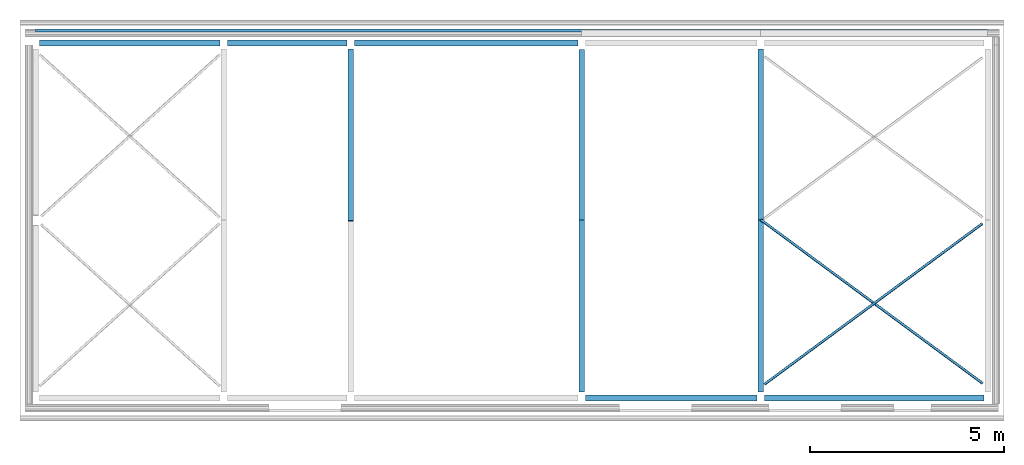
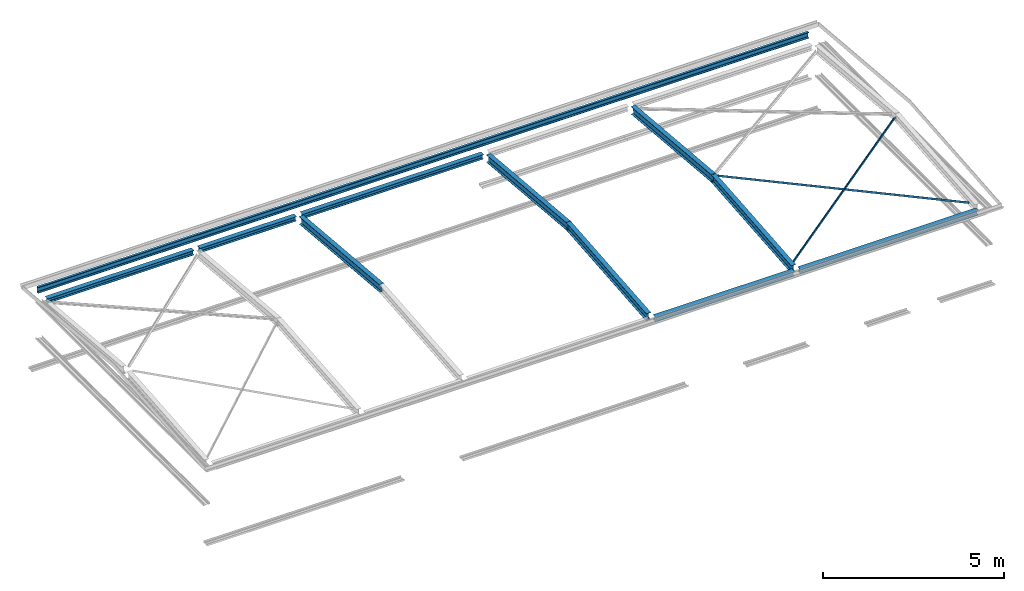
# One storey, part 2 of 8: 13 beams.
"""IFC2X3 building model written with IfcOpenShell, lengths in millimetres."""

import ifcopenshell
import ifcopenshell.guid

model = None  # the IFC model being written
_history = None  # IfcOwnerHistory: only IFC2X3 demands one
_inside = {}  # id of a spatial element -> (the spatial element, [elements in it])
_under = {}  # id of a project, library or spatial element -> (it, [spatial elements below it])
_declared = {}  # id of a project -> (the project, [libraries it declares])
_typed = {}  # id of a type object -> (the type object, [elements of that type])
_made_of = {}  # id of a material, layer set ... -> (it, [elements and type objects made of it])


def new_model(schema):
    """Start an empty IFC model of exactly this schema.

    Asked for "IFC4X3", IfcOpenShell would pick the latest addendum, in which some entities
    have other attributes; the version numbers below select the first issue.
    IFC2X3 requires an IfcOwnerHistory on every rooted entity: one is made here for all.
    """
    global model, _history
    if schema == "IFC4X3":
        model = ifcopenshell.file(schema_version=(4, 3, 0, 0))
    else:
        model = ifcopenshell.file(schema=schema)
    _inside.clear()
    _under.clear()
    _declared.clear()
    _typed.clear()
    _made_of.clear()
    _history = None
    if model.schema == "IFC2X3":
        org = make("IfcOrganization", Name="unknown")
        user = make(
            "IfcPersonAndOrganization",
            ThePerson=make("IfcPerson", FamilyName="unknown"),
            TheOrganization=org,
        )
        app = make(
            "IfcApplication",
            ApplicationDeveloper=org,
            Version="unknown",
            ApplicationFullName="unknown",
            ApplicationIdentifier="unknown",
        )
        _history = make(
            "IfcOwnerHistory",
            OwningUser=user,
            OwningApplication=app,
            ChangeAction="ADDED",
            CreationDate=0,
        )
    return model


def make(cls, **values):
    """One entity of the class cls with the attributes given. An attribute that is None is left unset."""
    return model.create_entity(
        cls, **{name: value for name, value in values.items() if value is not None}
    )


def entity(cls, *values):
    """Any entity or typed value of the class cls, its attributes in the order of the schema. None: left unset."""
    e = model.create_entity(cls)
    for i, value in enumerate(values):
        if value is not None:
            e[i] = value
    return e


def rooted(cls, **values):
    """An entity with a GlobalId (a new one), such as an element, a storey or a relation."""
    return make(cls, GlobalId=ifcopenshell.guid.new(), OwnerHistory=_history, **values)


def si_unit(unit_type, name, prefix=None):
    """IfcSIUnit, for example si_unit("LENGTHUNIT", "METRE", prefix="MILLI")."""
    return make("IfcSIUnit", UnitType=unit_type, Prefix=prefix, Name=name)


def converted_unit(unit_type, name, factor, base, dimensions=None, offset=None):
    """IfcConversionBasedUnit, such as the inch: factor (a typed value) times the base unit."""
    return make(
        "IfcConversionBasedUnit"
        if offset is None
        else "IfcConversionBasedUnitWithOffset",
        ConversionOffset=offset,
        Dimensions=None
        if dimensions is None
        else entity("IfcDimensionalExponents", *dimensions),
        UnitType=unit_type,
        Name=name,
        ConversionFactor=make(
            "IfcMeasureWithUnit", ValueComponent=factor, UnitComponent=base
        ),
    )


def money_unit(currency):
    """IfcMonetaryUnit."""
    return make("IfcMonetaryUnit", Currency=currency)


def assignment(units):
    """IfcUnitAssignment: the units of a project."""
    return None if units is None else make("IfcUnitAssignment", Units=units)


def point(xyz):
    """IfcCartesianPoint."""
    return None if xyz is None else make("IfcCartesianPoint", Coordinates=xyz)


def direction(xyz):
    """IfcDirection."""
    return None if xyz is None else make("IfcDirection", DirectionRatios=xyz)


def frame(location, z_axis=None, x_axis=None):
    """IfcAxis2Placement3D, a coordinate frame: its origin and axes. An axis left out is left unset."""
    return make(
        "IfcAxis2Placement3D",
        Location=point(location),
        Axis=direction(z_axis),
        RefDirection=direction(x_axis),
    )


def frame_2d(location, x_axis=None):
    """IfcAxis2Placement2D, a coordinate frame in the plane: its origin and x axis."""
    return make(
        "IfcAxis2Placement2D", Location=point(location), RefDirection=direction(x_axis)
    )


def origin_with_axes():
    """The frame at (0, 0, 0) with the z axis (0, 0, 1) and the x axis (1, 0, 0) written out."""
    return frame((0.0, 0.0, 0.0), z_axis=(0.0, 0.0, 1.0), x_axis=(1.0, 0.0, 0.0))


def place(relative_to, where):
    """IfcLocalPlacement: puts the frame where relative to a parent placement (None: the world)."""
    return make(
        "IfcLocalPlacement", PlacementRelTo=relative_to, RelativePlacement=where
    )


def context(
    kind, dimensions, precision=None, world=None, true_north=None, identifier=None
):
    """IfcGeometricRepresentationContext, for example the 3D "Model" context."""
    return make(
        "IfcGeometricRepresentationContext",
        ContextIdentifier=identifier,
        ContextType=kind,
        CoordinateSpaceDimension=dimensions,
        Precision=precision,
        WorldCoordinateSystem=world,
        TrueNorth=true_north,
    )


def subcontext(parent, identifier, kind, view, scale=None):
    """IfcGeometricRepresentationSubContext, for example "Body" below "Model"."""
    return make(
        "IfcGeometricRepresentationSubContext",
        ContextIdentifier=identifier,
        ContextType=kind,
        ParentContext=parent,
        TargetScale=scale,
        TargetView=view,
    )


def project(units=None, contexts=None):
    """IfcProject with its units and contexts."""
    return rooted(
        "IfcProject",
        Name="project",
        RepresentationContexts=contexts,
        UnitsInContext=assignment(units),
    )


def spatial(cls, under=None, at=None, **own):
    """A site, building, storey or space (cls), placed at a placement, below another one or the project."""
    s = rooted(cls, ObjectPlacement=at, **own)
    if under is not None:
        _under.setdefault(under.id(), (under, []))[1].append(s)
    return s


def polyline(points):
    """IfcPolyline through the points."""
    return make("IfcPolyline", Points=[point(p) for p in points])


def circle_curve(where, radius):
    """IfcCircle in the frame where."""
    return make("IfcCircle", Position=where, Radius=radius)


def parameter(value):
    """IfcParameterValue: where a trimmed curve begins or ends, as a parameter of its basis curve."""
    return model.create_entity("IfcParameterValue", value)


def trimmed(basis, trim1, trim2, sense, master):
    """IfcTrimmedCurve: the piece of a basis curve between two trims."""
    return make(
        "IfcTrimmedCurve",
        BasisCurve=basis,
        Trim1=trim1,
        Trim2=trim2,
        SenseAgreement=sense,
        MasterRepresentation=master,
    )


def segment(curve, same_sense, transition):
    """IfcCompositeCurveSegment."""
    return make(
        "IfcCompositeCurveSegment",
        Transition=transition,
        SameSense=same_sense,
        ParentCurve=curve,
    )


def composite_curve(segments, self_intersect=None):
    """IfcCompositeCurve: segments joined end to end."""
    return make("IfcCompositeCurve", Segments=segments, SelfIntersect=self_intersect)


def outline(outer, holes=None, kind="AREA"):
    """IfcArbitraryClosedProfileDef: a profile drawn as a closed curve; with holes, ...WithVoids."""
    if holes is None:
        return make("IfcArbitraryClosedProfileDef", ProfileType=kind, OuterCurve=outer)
    return make(
        "IfcArbitraryProfileDefWithVoids",
        ProfileType=kind,
        OuterCurve=outer,
        InnerCurves=holes,
    )


def extrude(swept, where, along, depth):
    """IfcExtrudedAreaSolid: the profile swept, set in the frame where, extruded along a direction by depth."""
    return make(
        "IfcExtrudedAreaSolid",
        SweptArea=swept,
        Position=where,
        ExtrudedDirection=direction(along),
        Depth=depth,
    )


def clip(a, b, op="DIFFERENCE"):
    """IfcBooleanClippingResult: the solid a cut by the half space b."""
    return make(
        "IfcBooleanClippingResult", Operator=op, FirstOperand=a, SecondOperand=b
    )


def halfspace(plane, agree):
    """IfcHalfSpaceSolid: all space on one side of the plane z = 0 of the frame plane."""
    return make(
        "IfcHalfSpaceSolid",
        BaseSurface=make("IfcPlane", Position=plane),
        AgreementFlag=agree,
    )


def shape(context_of_items, identifier, shape_type, items):
    """IfcShapeRepresentation: the items that make up one representation, for example the "Body"."""
    return make(
        "IfcShapeRepresentation",
        ContextOfItems=context_of_items,
        RepresentationIdentifier=identifier,
        RepresentationType=shape_type,
        Items=items,
    )


def material(Name=None, Category=None):
    """IfcMaterial."""
    return make("IfcMaterial", Name=Name, Category=Category)


def made_of(thing, what):
    """Note that an element or type object is made of a material, layer set ...; save() writes the relation."""
    if what is not None:
        _made_of.setdefault(what.id(), (what, []))[1].append(thing)
    return thing


def type_object(cls, material=None, **own):
    """A type object (cls), such as IfcWallType, which elements share."""
    return made_of(rooted(cls, **own), material)


def element(
    cls,
    number,
    at=None,
    inside=None,
    cuts=None,
    type_object=None,
    material=None,
    context=None,
    identifier="Body",
    shape_type=None,
    held_by="IfcProductDefinitionShape",
    body=None,
    shapes=None,
    **own,
):
    """One element of the class cls, such as IfcWall. Its Tag is "e" and its number.

    at: its placement. inside: the storey or other place that contains it. cuts: it is an
    opening in that element (IfcRelVoidsElement). A single representation is given by context,
    identifier, shape_type and body (its items); several are given by shapes. held_by: the class
    of the entity that holds the representations. save() writes the other relations.
    """
    e = rooted(cls, Tag="e%d" % number, ObjectPlacement=at, **own)
    if body is not None:
        shapes = [shape(context, identifier, shape_type, body)]
    if shapes is not None:
        e.Representation = make(held_by, Representations=shapes)
    if inside is not None:
        _inside.setdefault(inside.id(), (inside, []))[1].append(e)
    if cuts is not None:
        rooted(
            "IfcRelVoidsElement", RelatingBuildingElement=cuts, RelatedOpeningElement=e
        )
    if type_object is not None:
        _typed.setdefault(type_object.id(), (type_object, []))[1].append(e)
    return made_of(e, material)


def aggregate(whole, parts):
    """IfcRelAggregates: a whole, such as a stair, and the parts it consists of."""
    return rooted("IfcRelAggregates", RelatingObject=whole, RelatedObjects=parts)


def save(model, path):
    """Write the relations noted so far, then the file.

    IfcRelAggregates (storeys below a building ...), IfcRelContainedInSpatialStructure (elements
    in a storey), IfcRelDefinesByType, IfcRelAssociatesMaterial and IfcRelDeclares: one each for
    every whole, place, type object, material and project.
    """
    for whole, parts in _under.values():
        aggregate(whole, parts)
    for where, things in _inside.values():
        rooted(
            "IfcRelContainedInSpatialStructure",
            RelatedElements=things,
            RelatingStructure=where,
        )
    for kind, things in _typed.values():
        rooted("IfcRelDefinesByType", RelatedObjects=things, RelatingType=kind)
    for what, things in _made_of.values():
        rooted("IfcRelAssociatesMaterial", RelatedObjects=things, RelatingMaterial=what)
    for by, libraries in _declared.values():
        rooted("IfcRelDeclares", RelatingContext=by, RelatedDefinitions=libraries)
    model.write(path)


model = new_model("IFC2X3")

# Units and contexts
model_context = context("Model", 3, precision=1e-05, world=origin_with_axes(), true_north=direction((0.0, 1.0)))
body_context = subcontext(model_context, "Body", "Model", "MODEL_VIEW")
ifc_project = project(units=[si_unit("LENGTHUNIT", "METRE", prefix="MILLI"), si_unit("AREAUNIT", "SQUARE_METRE"), si_unit("VOLUMEUNIT", "CUBIC_METRE"), converted_unit("PLANEANGLEUNIT", "DEGREE", entity("IfcPlaneAngleMeasure", 0.0174532925199), si_unit("PLANEANGLEUNIT", "RADIAN"), dimensions=[0, 0, 0, 0, 0, 0, 0]), si_unit("SOLIDANGLEUNIT", "STERADIAN"), money_unit("USD"), converted_unit("TIMEUNIT", "Year", entity("IfcTimeMeasure", 31556926.0), si_unit("TIMEUNIT", "SECOND"), dimensions=[0, 0, 0, 0, 0, 0, 0]), si_unit("MASSUNIT", "GRAM"), si_unit("THERMODYNAMICTEMPERATUREUNIT", "DEGREE_CELSIUS"), si_unit("LUMINOUSINTENSITYUNIT", "LUMEN")], contexts=[model_context])

# Site, building, storey
site_placement = place(None, origin_with_axes())
site = spatial("IfcSite", under=ifc_project, at=site_placement, CompositionType="ELEMENT")
building_placement = place(site_placement, origin_with_axes())
building = spatial("IfcBuilding", under=site, at=building_placement, CompositionType="ELEMENT")
storey_placement = place(building_placement, frame((0.0, 0.0, 74215.0), z_axis=(0.0, 0.0, 1.0), x_axis=(1.0, 0.0, 0.0)))
storey = spatial("IfcBuildingStorey", under=building, at=storey_placement, CompositionType="ELEMENT", Elevation=74215.0)

# Beams
ifc_material = material(Name="Metal - Steel 43-275")
beam_type_1 = type_object("IfcBeamType", Name="UB254x146x31 (1) 251 x 146", PredefinedType="NOTDEFINED")
beam_1_placement = place(storey_placement, frame((5946.1957886, 3613.7891505, 267.014681752), z_axis=(0.0, 0.0, 1.0), x_axis=(-1.0, 0.0, 0.0)))
element("IfcBeam", 1, at=beam_1_placement, inside=storey, type_object=beam_type_1, material=ifc_material, Name="UB-Universal Beams:UB254x146x31", ObjectType="UB-Universal Beams:UB254x146x31", context=body_context, shape_type="Clipping", body=[
    clip(clip(clip(clip(extrude(outline(composite_curve([segment(polyline([(125.7, 73.05), (117.1, 73.05), (117.1, 10.6)]), True, "CONTINUOUS"), segment(trimmed(circle_curve(frame_2d((109.5, 10.6), x_axis=(0.0, -1.0)), 7.6), [point((117.1, 10.6)), parameter(90.0)], [point((109.5, 3.0)), parameter(0.0)], False, "CARTESIAN"), True, "CONTINUOUS"), segment(polyline([(109.5, 3.0), (-109.5, 3.0)]), True, "CONTINUOUS"), segment(trimmed(circle_curve(frame_2d((-109.5, 10.6), x_axis=(-1.0, 0.0)), 7.6), [point((-109.5, 3.0)), parameter(90.0)], [point((-117.1, 10.6)), parameter(0.0)], False, "CARTESIAN"), True, "CONTINUOUS"), segment(polyline([(-117.1, 10.6), (-117.1, 73.05), (-125.7, 73.05), (-125.7, -73.05), (-117.1, -73.05), (-117.1, -10.6)]), True, "CONTINUOUS"), segment(trimmed(circle_curve(frame_2d((-109.5, -10.6), x_axis=(0.0, 1.0)), 7.6), [point((-117.1, -10.6)), parameter(90.0)], [point((-109.5, -3.0)), parameter(0.0)], False, "CARTESIAN"), True, "CONTINUOUS"), segment(polyline([(-109.5, -3.0), (109.5, -3.0)]), True, "CONTINUOUS"), segment(trimmed(circle_curve(frame_2d((109.5, -10.6), x_axis=(1.0, 0.0)), 7.6), [point((109.5, -3.0)), parameter(90.0)], [point((117.1, -10.6)), parameter(0.0)], False, "CARTESIAN"), True, "CONTINUOUS"), segment(polyline([(117.1, -10.6), (117.1, -73.05), (125.7, -73.05), (125.7, 73.05)]), True, "CONTINUOUS")], self_intersect=False)), frame((0.0, 4482.93411635, -395.427760455), z_axis=(0.0, -0.996132286365, 0.08786619408), x_axis=(0.0, -0.08786619408, -0.996132286365)), (0.0, 0.0, 1.0), 4518.56524717), halfspace(frame((0.0, 4446.62488753, -392.225019424), z_axis=(0.0, -0.996132286365, 0.08786619408), x_axis=(0.0, -0.08786619408, -0.996132286365)), True)), halfspace(frame((0.0, 18.1546144043, -1.60137051527), z_axis=(0.0, 0.996132286365, -0.08786619408), x_axis=(0.0, 0.08786619408, 0.996132286365)), True)), halfspace(frame((0.0, 4464.77950194, 0.0), z_axis=(0.0, -1.0, 0.0), x_axis=(0.0, 0.0, -1.0)), True)), halfspace(frame((0.0, 0.0, 0.0), z_axis=(0.0, 1.0, 0.0), x_axis=(0.0, 0.0, 1.0)), True)),
])
beam_2_placement = place(storey_placement, frame((10556.4041262, 3541.17069288, 267.014681752), z_axis=(0.0, 0.0, 1.0), x_axis=(1.0, 0.0, 0.0)))
element("IfcBeam", 2, at=beam_2_placement, inside=storey, type_object=beam_type_1, material=ifc_material, Name="UB-Universal Beams:UB254x146x31", ObjectType="UB-Universal Beams:UB254x146x31", context=body_context, shape_type="Clipping", body=[
    clip(clip(clip(clip(extrude(outline(composite_curve([segment(polyline([(125.7, 73.05), (117.1, 73.05), (117.1, 10.6)]), True, "CONTINUOUS"), segment(trimmed(circle_curve(frame_2d((109.5, 10.6), x_axis=(0.0, -1.0)), 7.6), [point((117.1, 10.6)), parameter(90.0)], [point((109.5, 3.0)), parameter(0.0)], False, "CARTESIAN"), True, "CONTINUOUS"), segment(polyline([(109.5, 3.0), (-109.5, 3.0)]), True, "CONTINUOUS"), segment(trimmed(circle_curve(frame_2d((-109.5, 10.6), x_axis=(-1.0, 0.0)), 7.6), [point((-109.5, 3.0)), parameter(90.0)], [point((-117.1, 10.6)), parameter(0.0)], False, "CARTESIAN"), True, "CONTINUOUS"), segment(polyline([(-117.1, 10.6), (-117.1, 73.05), (-125.7, 73.05), (-125.7, -73.05), (-117.1, -73.05), (-117.1, -10.6)]), True, "CONTINUOUS"), segment(trimmed(circle_curve(frame_2d((-109.5, -10.6), x_axis=(0.0, 1.0)), 7.6), [point((-117.1, -10.6)), parameter(90.0)], [point((-109.5, -3.0)), parameter(0.0)], False, "CARTESIAN"), True, "CONTINUOUS"), segment(polyline([(-109.5, -3.0), (109.5, -3.0)]), True, "CONTINUOUS"), segment(trimmed(circle_curve(frame_2d((109.5, -10.6), x_axis=(1.0, 0.0)), 7.6), [point((109.5, -3.0)), parameter(90.0)], [point((117.1, -10.6)), parameter(0.0)], False, "CARTESIAN"), True, "CONTINUOUS"), segment(polyline([(117.1, -10.6), (117.1, -73.05), (125.7, -73.05), (125.7, 73.05)]), True, "CONTINUOUS")], self_intersect=False)), frame((0.0, 4482.93411635, -395.427760455), z_axis=(0.0, -0.996132286365, 0.08786619408), x_axis=(0.0, -0.08786619408, -0.996132286365)), (0.0, 0.0, 1.0), 4518.56524717), halfspace(frame((0.0, 4446.62488753, -392.225019424), z_axis=(0.0, -0.996132286365, 0.08786619408), x_axis=(0.0, -0.08786619408, -0.996132286365)), True)), halfspace(frame((0.0, 18.1546144043, -1.60137051527), z_axis=(0.0, 0.996132286365, -0.08786619408), x_axis=(0.0, 0.08786619408, 0.996132286365)), True)), halfspace(frame((0.0, 4464.77950194, 0.0), z_axis=(0.0, -1.0, 0.0), x_axis=(0.0, 0.0, -1.0)), True)), halfspace(frame((0.0, 0.0, 0.0), z_axis=(0.0, 1.0, 0.0), x_axis=(0.0, 0.0, 1.0)), True)),
])
beam_3_placement = place(storey_placement, frame((10556.4041262, 3613.7891505, 267.014681752), z_axis=(0.0, 0.0, 1.0), x_axis=(-1.0, 0.0, 0.0)))
element("IfcBeam", 3, at=beam_3_placement, inside=storey, type_object=beam_type_1, material=ifc_material, Name="UB-Universal Beams:UB254x146x31", ObjectType="UB-Universal Beams:UB254x146x31", context=body_context, shape_type="Clipping", body=[
    clip(clip(clip(clip(extrude(outline(composite_curve([segment(polyline([(125.7, 73.05), (117.1, 73.05), (117.1, 10.6)]), True, "CONTINUOUS"), segment(trimmed(circle_curve(frame_2d((109.5, 10.6), x_axis=(0.0, -1.0)), 7.6), [point((117.1, 10.6)), parameter(90.0)], [point((109.5, 3.0)), parameter(0.0)], False, "CARTESIAN"), True, "CONTINUOUS"), segment(polyline([(109.5, 3.0), (-109.5, 3.0)]), True, "CONTINUOUS"), segment(trimmed(circle_curve(frame_2d((-109.5, 10.6), x_axis=(-1.0, 0.0)), 7.6), [point((-109.5, 3.0)), parameter(90.0)], [point((-117.1, 10.6)), parameter(0.0)], False, "CARTESIAN"), True, "CONTINUOUS"), segment(polyline([(-117.1, 10.6), (-117.1, 73.05), (-125.7, 73.05), (-125.7, -73.05), (-117.1, -73.05), (-117.1, -10.6)]), True, "CONTINUOUS"), segment(trimmed(circle_curve(frame_2d((-109.5, -10.6), x_axis=(0.0, 1.0)), 7.6), [point((-117.1, -10.6)), parameter(90.0)], [point((-109.5, -3.0)), parameter(0.0)], False, "CARTESIAN"), True, "CONTINUOUS"), segment(polyline([(-109.5, -3.0), (109.5, -3.0)]), True, "CONTINUOUS"), segment(trimmed(circle_curve(frame_2d((109.5, -10.6), x_axis=(1.0, 0.0)), 7.6), [point((109.5, -3.0)), parameter(90.0)], [point((117.1, -10.6)), parameter(0.0)], False, "CARTESIAN"), True, "CONTINUOUS"), segment(polyline([(117.1, -10.6), (117.1, -73.05), (125.7, -73.05), (125.7, 73.05)]), True, "CONTINUOUS")], self_intersect=False)), frame((0.0, 4482.93411635, -395.427760455), z_axis=(0.0, -0.996132286365, 0.08786619408), x_axis=(0.0, -0.08786619408, -0.996132286365)), (0.0, 0.0, 1.0), 4518.56524717), halfspace(frame((0.0, 4446.62488753, -392.225019424), z_axis=(0.0, -0.996132286365, 0.08786619408), x_axis=(0.0, -0.08786619408, -0.996132286365)), True)), halfspace(frame((0.0, 18.1546144043, -1.60137051527), z_axis=(0.0, 0.996132286365, -0.08786619408), x_axis=(0.0, 0.08786619408, 0.996132286365)), True)), halfspace(frame((0.0, 4464.77950194, 0.0), z_axis=(0.0, -1.0, 0.0), x_axis=(0.0, 0.0, -1.0)), True)), halfspace(frame((0.0, 0.0, 0.0), z_axis=(0.0, 1.0, 0.0), x_axis=(0.0, 0.0, 1.0)), True)),
])
beam_4_placement = place(storey_placement, frame((5946.1957886, 3541.17069288, 267.014681752), z_axis=(0.0, 0.0, 1.0), x_axis=(1.0, 0.0, 0.0)))
element("IfcBeam", 4, at=beam_4_placement, inside=storey, type_object=beam_type_1, material=ifc_material, Name="UB-Universal Beams:UB254x146x31", ObjectType="UB-Universal Beams:UB254x146x31", context=body_context, shape_type="Clipping", body=[
    clip(clip(clip(extrude(outline(composite_curve([segment(polyline([(125.7, 73.05), (117.1, 73.05), (117.1, 10.6)]), True, "CONTINUOUS"), segment(trimmed(circle_curve(frame_2d((109.5, 10.6), x_axis=(0.0, -1.0)), 7.6), [point((117.1, 10.6)), parameter(90.0)], [point((109.5, 3.0)), parameter(0.0)], False, "CARTESIAN"), True, "CONTINUOUS"), segment(polyline([(109.5, 3.0), (-109.5, 3.0)]), True, "CONTINUOUS"), segment(trimmed(circle_curve(frame_2d((-109.5, 10.6), x_axis=(-1.0, 0.0)), 7.6), [point((-109.5, 3.0)), parameter(90.0)], [point((-117.1, 10.6)), parameter(0.0)], False, "CARTESIAN"), True, "CONTINUOUS"), segment(polyline([(-117.1, 10.6), (-117.1, 73.05), (-125.7, 73.05), (-125.7, -73.05), (-117.1, -73.05), (-117.1, -10.6)]), True, "CONTINUOUS"), segment(trimmed(circle_curve(frame_2d((-109.5, -10.6), x_axis=(0.0, 1.0)), 7.6), [point((-117.1, -10.6)), parameter(90.0)], [point((-109.5, -3.0)), parameter(0.0)], False, "CARTESIAN"), True, "CONTINUOUS"), segment(polyline([(-109.5, -3.0), (109.5, -3.0)]), True, "CONTINUOUS"), segment(trimmed(circle_curve(frame_2d((109.5, -10.6), x_axis=(1.0, 0.0)), 7.6), [point((109.5, -3.0)), parameter(90.0)], [point((117.1, -10.6)), parameter(0.0)], False, "CARTESIAN"), True, "CONTINUOUS"), segment(polyline([(117.1, -10.6), (117.1, -73.05), (125.7, -73.05), (125.7, 73.05)]), True, "CONTINUOUS")], self_intersect=False)), frame((0.0, 4455.86385661, -393.039964449), z_axis=(0.0, -0.996132286365, 0.08786619408), x_axis=(0.0, -0.08786619408, -0.996132286365)), (0.0, 0.0, 1.0), 4491.3898809), halfspace(frame((0.0, 18.1546144043, -1.60137051527), z_axis=(0.0, 0.996132286365, -0.08786619408), x_axis=(0.0, 0.08786619408, 0.996132286365)), True)), halfspace(frame((0.0, 4437.70924221, 0.0), z_axis=(0.0, -1.0, 0.0), x_axis=(0.0, 0.0, -1.0)), True)), halfspace(frame((0.0, 0.0, 0.0), z_axis=(0.0, 1.0, 0.0), x_axis=(0.0, 0.0, 1.0)), True)),
])
beam_5_placement = place(storey_placement, frame((-6.72084898816, 3541.17069288, 267.014681752), z_axis=(0.0, 0.0, 1.0), x_axis=(1.0, 0.0, 0.0)))
element("IfcBeam", 5, at=beam_5_placement, inside=storey, type_object=beam_type_1, material=ifc_material, Name="UB-Universal Beams:UB254x146x31", ObjectType="UB-Universal Beams:UB254x146x31", context=body_context, shape_type="Clipping", body=[
    clip(clip(clip(clip(extrude(outline(composite_curve([segment(polyline([(125.7, 73.05), (117.1, 73.05), (117.1, 10.6)]), True, "CONTINUOUS"), segment(trimmed(circle_curve(frame_2d((109.5, 10.6), x_axis=(0.0, -1.0)), 7.6), [point((117.1, 10.6)), parameter(90.0)], [point((109.5, 3.0)), parameter(0.0)], False, "CARTESIAN"), True, "CONTINUOUS"), segment(polyline([(109.5, 3.0), (-109.5, 3.0)]), True, "CONTINUOUS"), segment(trimmed(circle_curve(frame_2d((-109.5, 10.6), x_axis=(-1.0, 0.0)), 7.6), [point((-109.5, 3.0)), parameter(90.0)], [point((-117.1, 10.6)), parameter(0.0)], False, "CARTESIAN"), True, "CONTINUOUS"), segment(polyline([(-117.1, 10.6), (-117.1, 73.05), (-125.7, 73.05), (-125.7, -73.05), (-117.1, -73.05), (-117.1, -10.6)]), True, "CONTINUOUS"), segment(trimmed(circle_curve(frame_2d((-109.5, -10.6), x_axis=(0.0, 1.0)), 7.6), [point((-117.1, -10.6)), parameter(90.0)], [point((-109.5, -3.0)), parameter(0.0)], False, "CARTESIAN"), True, "CONTINUOUS"), segment(polyline([(-109.5, -3.0), (109.5, -3.0)]), True, "CONTINUOUS"), segment(trimmed(circle_curve(frame_2d((109.5, -10.6), x_axis=(1.0, 0.0)), 7.6), [point((109.5, -3.0)), parameter(90.0)], [point((117.1, -10.6)), parameter(0.0)], False, "CARTESIAN"), True, "CONTINUOUS"), segment(polyline([(117.1, -10.6), (117.1, -73.05), (125.7, -73.05), (125.7, 73.05)]), True, "CONTINUOUS")], self_intersect=False)), frame((0.0, 4482.93411635, -395.427760455), z_axis=(0.0, -0.996132286365, 0.08786619408), x_axis=(0.0, -0.08786619408, -0.996132286365)), (0.0, 0.0, 1.0), 4518.56524717), halfspace(frame((0.0, 4446.62488753, -392.225019424), z_axis=(0.0, -0.996132286365, 0.08786619408), x_axis=(0.0, -0.08786619408, -0.996132286365)), True)), halfspace(frame((0.0, 18.1546144043, -1.60137051527), z_axis=(0.0, 0.996132286365, -0.08786619408), x_axis=(0.0, 0.08786619408, 0.996132286365)), True)), halfspace(frame((0.0, 4464.77950194, 0.0), z_axis=(0.0, -1.0, 0.0), x_axis=(0.0, 0.0, -1.0)), True)), halfspace(frame((0.0, 0.0, 0.0), z_axis=(0.0, 1.0, 0.0), x_axis=(0.0, 0.0, 1.0)), True)),
])
beam_type_2 = type_object("IfcBeamType", Name="UC152x152x23 152 x 152", PredefinedType="NOTDEFINED")
beam_6_placement = place(storey_placement, frame((10461.1999574, -995.620091702, -116.2), z_axis=(0.0, 0.0, 1.0), x_axis=(0.0, 1.0, 0.0)))
element("IfcBeam", 6, at=beam_6_placement, inside=storey, type_object=beam_type_2, material=ifc_material, Name="UC-Universal Columns:UC152x152x23", ObjectType="UC-Universal Columns:UC152x152x23", context=body_context, shape_type="SweptSolid", body=[
    extrude(outline(composite_curve([segment(polyline([(76.2, 76.1), (69.4, 76.1), (69.4, 10.4999999999)]), True, "CONTINUOUS"), segment(trimmed(circle_curve(frame_2d((61.8, 10.4999999999), x_axis=(0.0, -1.0)), 7.60000000002), [point((69.4, 10.4999999999)), parameter(90.0)], [point((61.8, 2.89999999987)), parameter(0.0)], False, "CARTESIAN"), True, "CONTINUOUS"), segment(polyline([(61.8, 2.89999999987), (-61.8, 2.89999999987)]), True, "CONTINUOUS"), segment(trimmed(circle_curve(frame_2d((-61.8, 10.4999999999), x_axis=(-1.0, 0.0)), 7.60000000002), [point((-61.8, 2.89999999987)), parameter(90.0)], [point((-69.4, 10.4999999999)), parameter(0.0)], False, "CARTESIAN"), True, "CONTINUOUS"), segment(polyline([(-69.4, 10.4999999999), (-69.4, 76.1), (-76.2, 76.1), (-76.2, -76.1), (-69.4, -76.1), (-69.4, -10.4999999999)]), True, "CONTINUOUS"), segment(trimmed(circle_curve(frame_2d((-61.8, -10.4999999999), x_axis=(0.0, 1.0)), 7.60000000002), [point((-69.4, -10.4999999999)), parameter(90.0)], [point((-61.8, -2.89999999987)), parameter(0.0)], False, "CARTESIAN"), True, "CONTINUOUS"), segment(polyline([(-61.8, -2.89999999987), (61.8, -2.89999999987)]), True, "CONTINUOUS"), segment(trimmed(circle_curve(frame_2d((61.8, -10.4999999999), x_axis=(1.0, 0.0)), 7.60000000002), [point((61.8, -2.89999999987)), parameter(90.0)], [point((69.4, -10.4999999999)), parameter(0.0)], False, "CARTESIAN"), True, "CONTINUOUS"), segment(polyline([(69.4, -10.4999999999), (69.4, -76.1), (76.2, -76.1), (76.2, 76.1)]), True, "CONTINUOUS")], self_intersect=False)), frame((0.0, 4419.8, 0.0), z_axis=(0.0, -1.0, 0.0), x_axis=(0.0, 0.0, -1.0)), (0.0, 0.0, 1.0), 4419.8),
])
beam_7_placement = place(storey_placement, frame((16313.0418012, -995.620091702, -116.2), z_axis=(0.0, 0.0, 1.0), x_axis=(0.0, 1.0, 0.0)))
element("IfcBeam", 7, at=beam_7_placement, inside=storey, type_object=beam_type_2, material=ifc_material, Name="UC-Universal Columns:UC152x152x23", ObjectType="UC-Universal Columns:UC152x152x23", context=body_context, shape_type="SweptSolid", body=[
    extrude(outline(composite_curve([segment(polyline([(76.2, 76.1), (69.4, 76.1), (69.4, 10.4999999999)]), True, "CONTINUOUS"), segment(trimmed(circle_curve(frame_2d((61.8, 10.4999999999), x_axis=(0.0, -1.0)), 7.60000000002), [point((69.4, 10.4999999999)), parameter(90.0)], [point((61.8, 2.89999999987)), parameter(0.0)], False, "CARTESIAN"), True, "CONTINUOUS"), segment(polyline([(61.8, 2.89999999987), (-61.8, 2.89999999987)]), True, "CONTINUOUS"), segment(trimmed(circle_curve(frame_2d((-61.8, 10.4999999999), x_axis=(-1.0, 0.0)), 7.60000000002), [point((-61.8, 2.89999999987)), parameter(90.0)], [point((-69.4, 10.4999999999)), parameter(0.0)], False, "CARTESIAN"), True, "CONTINUOUS"), segment(polyline([(-69.4, 10.4999999999), (-69.4, 76.1), (-76.2, 76.1), (-76.2, -76.1), (-69.4, -76.1), (-69.4, -10.4999999999)]), True, "CONTINUOUS"), segment(trimmed(circle_curve(frame_2d((-61.8, -10.4999999999), x_axis=(0.0, 1.0)), 7.60000000002), [point((-69.4, -10.4999999999)), parameter(90.0)], [point((-61.8, -2.89999999987)), parameter(0.0)], False, "CARTESIAN"), True, "CONTINUOUS"), segment(polyline([(-61.8, -2.89999999987), (61.8, -2.89999999987)]), True, "CONTINUOUS"), segment(trimmed(circle_curve(frame_2d((61.8, -10.4999999999), x_axis=(1.0, 0.0)), 7.60000000002), [point((61.8, -2.89999999987)), parameter(90.0)], [point((69.4, -10.4999999999)), parameter(0.0)], False, "CARTESIAN"), True, "CONTINUOUS"), segment(polyline([(69.4, -10.4999999999), (69.4, -76.1), (76.2, -76.1), (76.2, 76.1)]), True, "CONTINUOUS")], self_intersect=False)), frame((0.0, 5661.4, 0.0), z_axis=(0.0, -1.0, 0.0), x_axis=(0.0, 0.0, -1.0)), (0.0, 0.0, 1.0), 5661.4),
])
beam_8_placement = place(storey_placement, frame((-3369.44567394, 8150.57993509, -116.2), z_axis=(0.0, 0.0, 1.0), x_axis=(0.0, 1.0, 0.0)))
element("IfcBeam", 8, at=beam_8_placement, inside=storey, type_object=beam_type_2, material=ifc_material, Name="UC-Universal Columns:UC152x152x23", ObjectType="UC-Universal Columns:UC152x152x23", context=body_context, shape_type="SweptSolid", body=[
    extrude(outline(composite_curve([segment(polyline([(76.2, 76.1), (69.4, 76.1), (69.4, 10.4999999999)]), True, "CONTINUOUS"), segment(trimmed(circle_curve(frame_2d((61.8, 10.4999999999), x_axis=(0.0, -1.0)), 7.60000000002), [point((69.4, 10.4999999999)), parameter(90.0)], [point((61.8, 2.89999999987)), parameter(0.0)], False, "CARTESIAN"), True, "CONTINUOUS"), segment(polyline([(61.8, 2.89999999987), (-61.8, 2.89999999987)]), True, "CONTINUOUS"), segment(trimmed(circle_curve(frame_2d((-61.8, 10.4999999999), x_axis=(-1.0, 0.0)), 7.60000000002), [point((-61.8, 2.89999999987)), parameter(90.0)], [point((-69.4, 10.4999999999)), parameter(0.0)], False, "CARTESIAN"), True, "CONTINUOUS"), segment(polyline([(-69.4, 10.4999999999), (-69.4, 76.1), (-76.2, 76.1), (-76.2, -76.1), (-69.4, -76.1), (-69.4, -10.4999999999)]), True, "CONTINUOUS"), segment(trimmed(circle_curve(frame_2d((-61.8, -10.4999999999), x_axis=(0.0, 1.0)), 7.60000000002), [point((-69.4, -10.4999999999)), parameter(90.0)], [point((-61.8, -2.89999999987)), parameter(0.0)], False, "CARTESIAN"), True, "CONTINUOUS"), segment(polyline([(-61.8, -2.89999999987), (61.8, -2.89999999987)]), True, "CONTINUOUS"), segment(trimmed(circle_curve(frame_2d((61.8, -10.4999999999), x_axis=(1.0, 0.0)), 7.60000000002), [point((61.8, -2.89999999987)), parameter(90.0)], [point((69.4, -10.4999999999)), parameter(0.0)], False, "CARTESIAN"), True, "CONTINUOUS"), segment(polyline([(69.4, -10.4999999999), (69.4, -76.1), (76.2, -76.1), (76.2, 76.1)]), True, "CONTINUOUS")], self_intersect=False)), frame((0.0, 4655.2, 0.0), z_axis=(0.0, -1.0, 0.0), x_axis=(0.0, 0.0, -1.0)), (0.0, 0.0, 1.0), 4655.2),
])
beam_9_placement = place(storey_placement, frame((-101.92086778, 8150.57993509, -116.2), z_axis=(0.0, 0.0, 1.0), x_axis=(0.0, 1.0, 0.0)))
element("IfcBeam", 9, at=beam_9_placement, inside=storey, type_object=beam_type_2, material=ifc_material, Name="UC-Universal Columns:UC152x152x23", ObjectType="UC-Universal Columns:UC152x152x23", context=body_context, shape_type="SweptSolid", body=[
    extrude(outline(composite_curve([segment(polyline([(76.2, 76.1), (69.4, 76.1), (69.4, 10.4999999999)]), True, "CONTINUOUS"), segment(trimmed(circle_curve(frame_2d((61.8, 10.4999999999), x_axis=(0.0, -1.0)), 7.60000000002), [point((69.4, 10.4999999999)), parameter(90.0)], [point((61.8, 2.89999999987)), parameter(0.0)], False, "CARTESIAN"), True, "CONTINUOUS"), segment(polyline([(61.8, 2.89999999987), (-61.8, 2.89999999987)]), True, "CONTINUOUS"), segment(trimmed(circle_curve(frame_2d((-61.8, 10.4999999999), x_axis=(-1.0, 0.0)), 7.60000000002), [point((-61.8, 2.89999999987)), parameter(90.0)], [point((-69.4, 10.4999999999)), parameter(0.0)], False, "CARTESIAN"), True, "CONTINUOUS"), segment(polyline([(-69.4, 10.4999999999), (-69.4, 76.1), (-76.2, 76.1), (-76.2, -76.1), (-69.4, -76.1), (-69.4, -10.4999999999)]), True, "CONTINUOUS"), segment(trimmed(circle_curve(frame_2d((-61.8, -10.4999999999), x_axis=(0.0, 1.0)), 7.60000000002), [point((-69.4, -10.4999999999)), parameter(90.0)], [point((-61.8, -2.89999999987)), parameter(0.0)], False, "CARTESIAN"), True, "CONTINUOUS"), segment(polyline([(-61.8, -2.89999999987), (61.8, -2.89999999987)]), True, "CONTINUOUS"), segment(trimmed(circle_curve(frame_2d((61.8, -10.4999999999), x_axis=(1.0, 0.0)), 7.60000000002), [point((61.8, -2.89999999987)), parameter(90.0)], [point((69.4, -10.4999999999)), parameter(0.0)], False, "CARTESIAN"), True, "CONTINUOUS"), segment(polyline([(69.4, -10.4999999999), (69.4, -76.1), (76.2, -76.1), (76.2, 76.1)]), True, "CONTINUOUS")], self_intersect=False)), frame((0.0, 3077.1, 0.0), z_axis=(0.0, -1.0, 0.0), x_axis=(0.0, 0.0, -1.0)), (0.0, 0.0, 1.0), 3077.1),
])
beam_10_placement = place(storey_placement, frame((5850.9874698, 8150.57993509, -116.2), z_axis=(0.0, 0.0, 1.0), x_axis=(0.0, 1.0, 0.0)))
element("IfcBeam", 10, at=beam_10_placement, inside=storey, type_object=beam_type_2, material=ifc_material, Name="UC-Universal Columns:UC152x152x23", ObjectType="UC-Universal Columns:UC152x152x23", context=body_context, shape_type="SweptSolid", body=[
    extrude(outline(composite_curve([segment(polyline([(76.2, 76.1), (69.4, 76.1), (69.4, 10.4999999999)]), True, "CONTINUOUS"), segment(trimmed(circle_curve(frame_2d((61.8, 10.4999999999), x_axis=(0.0, -1.0)), 7.60000000002), [point((69.4, 10.4999999999)), parameter(90.0)], [point((61.8, 2.89999999987)), parameter(0.0)], False, "CARTESIAN"), True, "CONTINUOUS"), segment(polyline([(61.8, 2.89999999987), (-61.8, 2.89999999987)]), True, "CONTINUOUS"), segment(trimmed(circle_curve(frame_2d((-61.8, 10.4999999999), x_axis=(-1.0, 0.0)), 7.60000000002), [point((-61.8, 2.89999999987)), parameter(90.0)], [point((-69.4, 10.4999999999)), parameter(0.0)], False, "CARTESIAN"), True, "CONTINUOUS"), segment(polyline([(-69.4, 10.4999999999), (-69.4, 76.1), (-76.2, 76.1), (-76.2, -76.1), (-69.4, -76.1), (-69.4, -10.4999999999)]), True, "CONTINUOUS"), segment(trimmed(circle_curve(frame_2d((-61.8, -10.4999999999), x_axis=(0.0, 1.0)), 7.60000000002), [point((-69.4, -10.4999999999)), parameter(90.0)], [point((-61.8, -2.89999999987)), parameter(0.0)], False, "CARTESIAN"), True, "CONTINUOUS"), segment(polyline([(-61.8, -2.89999999987), (61.8, -2.89999999987)]), True, "CONTINUOUS"), segment(trimmed(circle_curve(frame_2d((61.8, -10.4999999999), x_axis=(1.0, 0.0)), 7.60000000002), [point((61.8, -2.89999999987)), parameter(90.0)], [point((69.4, -10.4999999999)), parameter(0.0)], False, "CARTESIAN"), True, "CONTINUOUS"), segment(polyline([(69.4, -10.4999999999), (69.4, -76.1), (76.2, -76.1), (76.2, 76.1)]), True, "CONTINUOUS")], self_intersect=False)), frame((0.0, 5762.5, 0.0), z_axis=(0.0, -1.0, 0.0), x_axis=(0.0, 0.0, -1.0)), (0.0, 0.0, 1.0), 5762.5),
])
beam_type_3 = type_object("IfcBeamType", Name="L70x70x7 70 x 70", PredefinedType="NOTDEFINED")
beam_11_placement = place(storey_placement, frame((10551.1782699, 3589.80441426, 346.993096618), z_axis=(0.0, 0.0, 1.0), x_axis=(-0.593453056402, -0.804868604089, 0.0)))
element("IfcBeam", 11, at=beam_11_placement, inside=storey, type_object=beam_type_3, material=ifc_material, Name="L-Equal Leg Angles:L70x70x7", ObjectType="L-Equal Leg Angles:L70x70x7", context=body_context, shape_type="Clipping", body=[
    clip(clip(clip(clip(extrude(outline(composite_curve([segment(polyline([(23.9444444444, -43.5555555556), (26.4444444444, -43.5555555556), (26.4444444444, 26.4444444444), (-43.5555555556, 26.4444444445), (-43.5555555556, 23.9444444445)]), True, "CONTINUOUS"), segment(trimmed(circle_curve(frame_2d((-39.0555555556, 23.9444444445), x_axis=(-1.0, 0.0)), 4.5), [point((-43.5555555556, 23.9444444445)), parameter(0.0)], [point((-39.0555555555, 19.4444444445)), parameter(90.0000000013)], True, "CARTESIAN"), True, "CONTINUOUS"), segment(polyline([(-39.0555555555, 19.4444444445), (10.4444444444, 19.4444444444)]), True, "CONTINUOUS"), segment(trimmed(circle_curve(frame_2d((10.4444444444, 10.4444444444), x_axis=(1.0, 0.0)), 9.0), [point((10.4444444444, 19.4444444444)), parameter(90.0)], [point((19.4444444444, 10.4444444444)), parameter(0.0)], False, "CARTESIAN"), True, "CONTINUOUS"), segment(polyline([(19.4444444444, 10.4444444444), (19.4444444444, -39.0555555556)]), True, "CONTINUOUS"), segment(trimmed(circle_curve(frame_2d((23.9444444444, -39.0555555556), x_axis=(-1.0, 0.0)), 4.5), [point((19.4444444444, -39.0555555556)), parameter(0.0)], [point((23.9444444444, -43.5555555556)), parameter(90.0)], True, "CARTESIAN"), True, "CONTINUOUS")], self_intersect=False)), frame((0.0, 7119.99780624, -372.709986495), z_axis=(0.0, -0.998632709103, 0.0522753508711), x_axis=(0.0, -0.0522753508711, -0.998632709103)), (0.0, 0.0, 1.0), 7134.9283245), halfspace(frame((0.0, 7109.64781482, -372.168196277), z_axis=(0.0, -0.998632709103, 0.0522753508711), x_axis=(0.0, -0.0522753508711, -0.998632709103)), True)), halfspace(frame((0.0, 5.1749957126, -0.270895109049), z_axis=(0.0, 0.998632709103, -0.0522753508711), x_axis=(0.0, 0.0522753508711, 0.998632709103)), True)), halfspace(frame((0.0, 7114.82281053, 0.0), z_axis=(0.0, -1.0, 0.0), x_axis=(0.0, 0.0, -1.0)), True)), halfspace(frame((0.0, 0.0, 0.0), z_axis=(0.0, 1.0, 0.0), x_axis=(0.0, 0.0, 1.0)), True)),
])
beam_type_4 = type_object("IfcBeamType", Name="L70x70x7 (1) 70 x 70", PredefinedType="NOTDEFINED")
beam_12_placement = place(storey_placement, frame((16281.1286039, 3492.10744099, 338.375505027), z_axis=(0.0, 0.0, 1.0), x_axis=(-0.593453056402, 0.804868604089, 0.0)))
element("IfcBeam", 12, at=beam_12_placement, inside=storey, type_object=beam_type_4, material=ifc_material, Name="L-Equal Leg Angles:L70x70x7", ObjectType="L-Equal Leg Angles:L70x70x7", context=body_context, shape_type="Clipping", body=[
    clip(clip(clip(clip(extrude(outline(composite_curve([segment(polyline([(-43.5555555556, -26.4444444444), (26.4444444444, -26.4444444444), (26.4444444444, 43.5555555556), (23.9444444444, 43.5555555556)]), True, "CONTINUOUS"), segment(trimmed(circle_curve(frame_2d((23.9444444444, 39.0555555556), x_axis=(0.0, 1.0)), 4.5), [point((23.9444444444, 43.5555555556)), parameter(0.0)], [point((19.4444444444, 39.0555555555)), parameter(90.0000000013)], True, "CARTESIAN"), True, "CONTINUOUS"), segment(polyline([(19.4444444444, 39.0555555555), (19.4444444444, -10.4444444444)]), True, "CONTINUOUS"), segment(trimmed(circle_curve(frame_2d((10.4444444444, -10.4444444444), x_axis=(0.0, -1.0)), 9.0), [point((19.4444444444, -10.4444444444)), parameter(90.0)], [point((10.4444444444, -19.4444444444)), parameter(0.0)], False, "CARTESIAN"), True, "CONTINUOUS"), segment(polyline([(10.4444444444, -19.4444444444), (-39.0555555556, -19.4444444444)]), True, "CONTINUOUS"), segment(trimmed(circle_curve(frame_2d((-39.0555555556, -23.9444444443), x_axis=(0.0, 1.0)), 4.49999999995), [point((-39.0555555556, -19.4444444444)), parameter(0.0)], [point((-43.5555555555, -23.9444444445)), parameter(90.0000000013)], True, "CARTESIAN"), True, "CONTINUOUS"), segment(polyline([(-43.5555555555, -23.9444444445), (-43.5555555556, -26.4444444444)]), True, "CONTINUOUS")], self_intersect=False)), frame((0.0, 6997.76516264, -366.311483548), z_axis=(0.0, -0.998632709103, 0.0522753508711), x_axis=(0.0, -0.0522753508711, -0.998632709103)), (0.0, 0.0, 1.0), 7012.5283245), halfspace(frame((0.0, 6987.41517122, -365.76969333), z_axis=(0.0, -0.998632709103, 0.0522753508711), x_axis=(0.0, -0.0522753508711, -0.998632709103)), True)), halfspace(frame((0.0, 5.17499571258, -0.270895109048), z_axis=(0.0, 0.998632709103, -0.0522753508711), x_axis=(0.0, 0.0522753508711, 0.998632709103)), True)), halfspace(frame((0.0, 6992.59016693, 0.0), z_axis=(0.0, -1.0, 0.0), x_axis=(0.0, 0.0, -1.0)), True)), halfspace(frame((0.0, 0.0, 0.0), z_axis=(0.0, 1.0, 0.0), x_axis=(0.0, 0.0, 1.0)), True)),
])
beam_type_5 = type_object("IfcBeamType", Name="PFC200x75x23 (3) 200 x 75", PredefinedType="NOTDEFINED")
beam_13_placement = place(storey_placement, frame((16408.2545075, 8472.47990658, 60.0), z_axis=(0.0, 0.0, 1.0), x_axis=(0.0, 1.0, 0.0)))
element("IfcBeam", 13, at=beam_13_placement, inside=storey, type_object=beam_type_5, material=ifc_material, Name="PFC-Parallel Flange Channels:PFC200x75x23", ObjectType="PFC-Parallel Flange Channels:PFC200x75x23", context=body_context, shape_type="SweptSolid", body=[
    extrude(outline(composite_curve([segment(polyline([(-100.0, -40.1999999994), (-87.5000000003, -40.1999999994), (-87.4999999999, 16.8000000006)]), True, "CONTINUOUS"), segment(trimmed(circle_curve(frame_2d((-75.5, 16.8000000006), x_axis=(0.0, 1.0)), 11.9999999999), [point((-87.4999999999, 16.8000000006)), parameter(90.0000000005)], [point((-75.4999999999, 28.8000000005)), parameter(0.0)], False, "CARTESIAN"), True, "CONTINUOUS"), segment(polyline([(-75.4999999999, 28.8000000005), (75.5000000002, 28.7999999996)]), True, "CONTINUOUS"), segment(trimmed(circle_curve(frame_2d((75.5000000001, 16.7999999996), x_axis=(1.0, 0.0)), 12.0), [point((75.5000000002, 28.7999999996)), parameter(90.0)], [point((87.5000000001, 16.7999999995)), parameter(0.0)], False, "CARTESIAN"), True, "CONTINUOUS"), segment(polyline([(87.5000000001, 16.7999999995), (87.4999999998, -40.2000000005), (100.0, -40.2000000006), (100.0, 34.7999999994), (-100.0, 34.8000000007), (-100.0, -40.1999999994)]), True, "CONTINUOUS")], self_intersect=False)), frame((0.0, 24528.1, 0.0), z_axis=(0.0, -1.0, 0.0), x_axis=(0.0, 0.0, -1.0)), (0.0, 0.0, 1.0), 24528.1),
])

save(model, "model.ifc")
